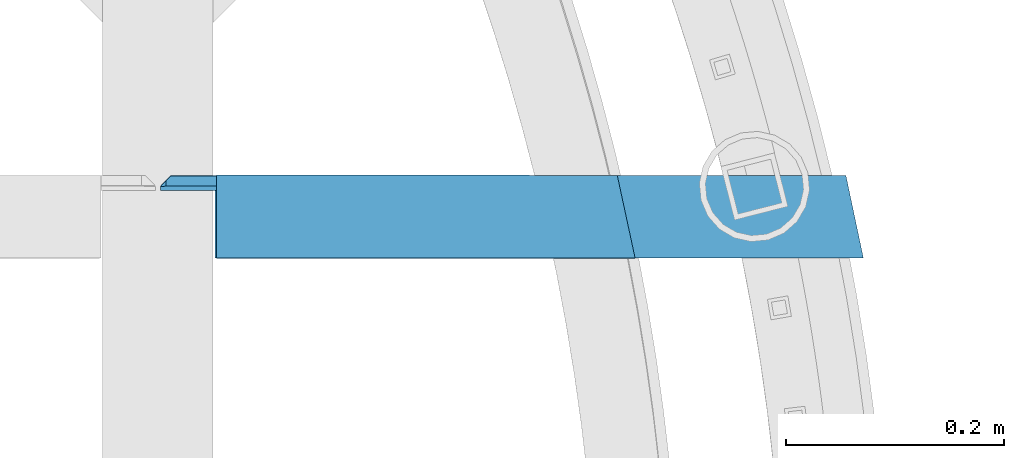
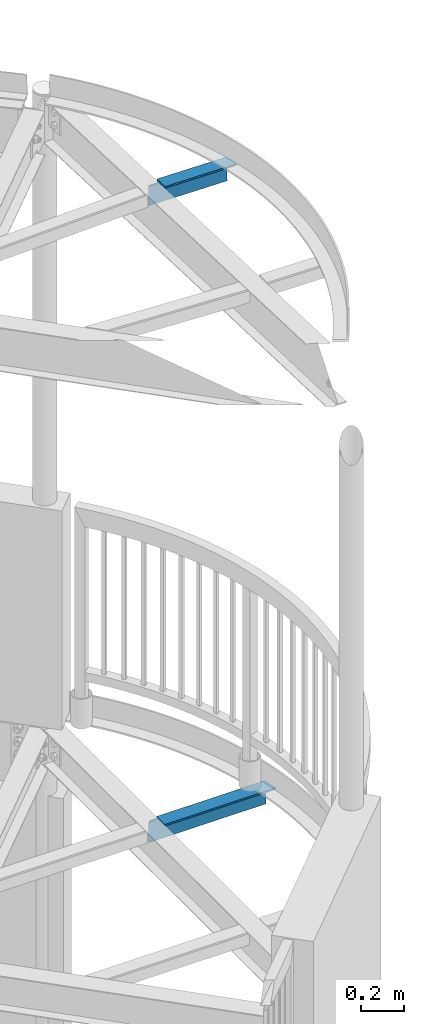
# One storey, part 526 of 975: 2 beams.
"""IFC2X3 building model written with IfcOpenShell, lengths in millimetres."""

from ifc_helpers import new_model, si_unit, frame, origin_with_axes, place, context, subcontext, project, spatial, faceted_brep, material, type_object, element, save


model = new_model("IFC2X3")

# Units and contexts
model_context = context("Model", 3, precision=1e-05, world=origin_with_axes())
body_context = subcontext(model_context, "Body", "Model", "MODEL_VIEW")
ifc_project = project(units=[si_unit("LENGTHUNIT", "METRE", prefix="MILLI"), si_unit("AREAUNIT", "SQUARE_METRE"), si_unit("VOLUMEUNIT", "CUBIC_METRE"), si_unit("MASSUNIT", "GRAM", prefix="KILO"), si_unit("TIMEUNIT", "SECOND"), si_unit("PLANEANGLEUNIT", "RADIAN"), si_unit("SOLIDANGLEUNIT", "STERADIAN"), si_unit("THERMODYNAMICTEMPERATUREUNIT", "DEGREE_CELSIUS"), si_unit("LUMINOUSINTENSITYUNIT", "LUMEN")], contexts=[model_context])

# Site, building, storey
site_placement = place(None, origin_with_axes())
site = spatial("IfcSite", under=ifc_project, at=site_placement, CompositionType="ELEMENT")
building_placement = place(site_placement, origin_with_axes())
building = spatial("IfcBuilding", under=site, at=building_placement, Name="Undefined", CompositionType="ELEMENT")
storey_placement = place(building_placement, origin_with_axes())
storey = spatial("IfcBuildingStorey", under=building, at=storey_placement, Name="Undefined", CompositionType="ELEMENT", Elevation=0.0)

# Beams
ifc_material = material(Name="STEEL/A36")
beam_type = type_object("IfcBeamType", Name="L5X3X3/8", PredefinedType="NOTDEFINED")
beam_1_placement = place(storey_placement, frame((36170.2030490712, 12106.8041668458, 3873.5), z_axis=(0.0, 0.0, -1.0), x_axis=(-0.999999999999998, 6.90000001668524e-08, 0.0)))
element("IfcBeam", 1, at=beam_1_placement, inside=storey, type_object=beam_type, material=ifc_material, Name="ANGLE", ObjectType="L5X3X3/8", context=body_context, shape_type="Brep", body=[
    faceted_brep([(630.04679755438, 28.5750000000007, 63.4999984741212), (630.04679755438, 28.5750000000007, -41.2750001907348), (620.521797260124, 38.1000000000004, -50.8000004849919), (620.521797260124, 38.1000000000004, 63.5), (-16.1234359523514, -38.1000000000004, -53.9749999999999), (-16.1234359523514, -38.1000000000004, -63.5), (580.040549080259, -38.1000000000004, -63.5), (580.040549080259, -38.1000000000004, -53.9749999999999), (5.0931703299284e-11, 38.0999999999999, -63.5000000000255), (580.040549080259, 38.1000000000004, -63.5), (580.040549080259, 28.5750000000007, -53.9749999999999), (580.040549080259, 38.1000000000004, -53.9749999999999), (617.346797745115, 38.1000000000004, -53.9749999999999), (617.346797745115, 28.5750000000007, -53.9749999999999), (-2.01542949404393, 28.5750000000007, -53.9749999999999), (-2.01542949404393, 28.5750000000007, 63.5), (-4.72937244921923e-11, 38.0999999999999, 63.5000000000182)], [[[0, 1, 2, 3]], [[4, 5, 6, 7]], [[5, 8, 9, 6]], [[10, 11, 12, 13]], [[7, 6, 9, 11, 10]], [[14, 4, 7, 10]], [[5, 4, 14, 15, 16, 8]], [[16, 15, 0, 3]], [[12, 11, 9, 8, 16, 3, 2]], [[13, 12, 2, 1]], [[15, 14, 10, 13, 1, 0]]]),
])
beam_2_placement = place(storey_placement, frame((35895.6591993284, 12104.6644022345, 7491.72182862674), z_axis=(-0.0132833128364073, -0.0348964179881241, -0.999302653659885), x_axis=(-0.999911772908035, 0.000463580999957693, 0.0132752209987788)))
element("IfcBeam", 2, at=beam_2_placement, inside=storey, type_object=beam_type, material=ifc_material, Name="ANGLE", ObjectType="L5X3X3/8", context=body_context, shape_type="Brep", body=[
    faceted_brep([(-80.0607370892103, -38.0999999999894, -53.9750000000076), (-79.9342023684731, -38.0999999999876, -63.5000000000036), (304.954594949108, -38.0999999999349, -63.4999999998399), (304.828060230546, -38.0999999999385, -53.9749999998439), (-63.5056029507614, 38.1000000000113, -63.5000000000073), (304.954594953873, 38.1000000000604, -63.4999999998508), (304.828060234722, 28.5750000000571, -53.974999999853), (304.698678936154, 38.1000000000549, -44.2357214325057), (304.698678935572, 28.5750000000553, -44.2357214318399), (-65.6857125987081, 28.5750000000098, -53.9750000000095), (-67.2463074878469, 28.5749999999753, 63.4999999999418), (-65.1927325606302, 38.0999999999713, 63.4999999999418), (345.16491186303, 38.1000000000258, 63.5000000001164), (346.58873277255, 38.1000000000604, -43.6792336452254), (351.038026586015, 28.5750000000626, -43.6201270681231), (351.038026586299, 33.6503135735875, -43.6201270684724), (356.045475722458, 28.574999676006, -38.4778442605293), (354.690752299677, 28.5750000000298, 63.5000000001237)], [[[0, 1, 2, 3]], [[1, 4, 5, 2]], [[6, 3, 2, 5, 7, 8]], [[9, 0, 3, 6]], [[1, 0, 9, 10, 11, 4]], [[7, 5, 4, 11, 12, 13]], [[14, 8, 7, 13, 15]], [[14, 15, 16]], [[10, 9, 6, 8, 14, 16, 17]], [[11, 10, 17, 12]], [[16, 15, 13, 12, 17]]]),
])

save(model, "model.ifc")
